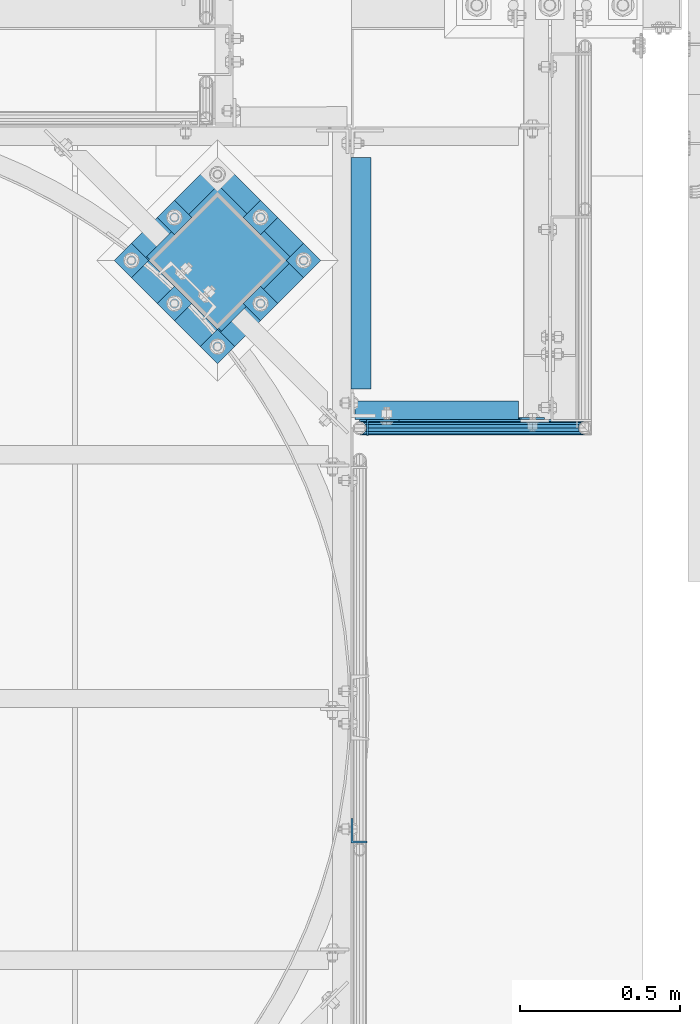
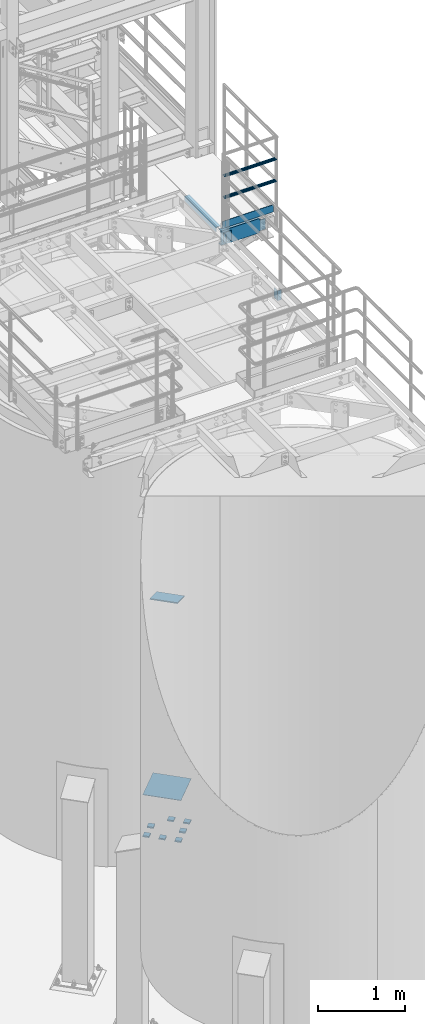
# One storey, part 1143 of 1876: 15 beams, 1 member, 6 elements without a shape of their own.
"""IFC2X3 building model written with IfcOpenShell, lengths in millimetres."""

from ifc_helpers import new_model, si_unit, frame, origin_with_axes, place, context, subcontext, project, spatial, faceted_brep, material, type_object, element, aggregate, save


model = new_model("IFC2X3")

# Units and contexts
model_context = context("Model", 3, precision=1e-05, world=origin_with_axes())
body_context = subcontext(model_context, "Body", "Model", "MODEL_VIEW")
ifc_project = project(units=[si_unit("LENGTHUNIT", "METRE", prefix="MILLI"), si_unit("AREAUNIT", "SQUARE_METRE"), si_unit("VOLUMEUNIT", "CUBIC_METRE"), si_unit("MASSUNIT", "GRAM", prefix="KILO"), si_unit("TIMEUNIT", "SECOND"), si_unit("PLANEANGLEUNIT", "RADIAN"), si_unit("SOLIDANGLEUNIT", "STERADIAN"), si_unit("THERMODYNAMICTEMPERATUREUNIT", "DEGREE_CELSIUS"), si_unit("LUMINOUSINTENSITYUNIT", "LUMEN")], contexts=[model_context])

# Site, building, storey
site_placement = place(None, origin_with_axes())
site = spatial("IfcSite", under=ifc_project, at=site_placement, CompositionType="ELEMENT")
building_placement = place(site_placement, origin_with_axes())
building = spatial("IfcBuilding", under=site, at=building_placement, Name="Undefined", CompositionType="ELEMENT")
storey_placement = place(building_placement, origin_with_axes())
storey = spatial("IfcBuildingStorey", under=building, at=storey_placement, Name="Undefined", CompositionType="ELEMENT", Elevation=0.0)

# Assembly, beams
assembly_1_placement = place(storey_placement, origin_with_axes())
assembly_1 = element("IfcElementAssembly", 1, at=assembly_1_placement, inside=storey, Name="HANDRAIL", AssemblyPlace="NOTDEFINED", PredefinedType="RIGID_FRAME")
ifc_material_1 = material(Name="STEEL/A36")
beam_type_1 = type_object("IfcBeamType", PredefinedType="NOTDEFINED")
beam_1_placement = place(assembly_1_placement, frame((7049.39088293518, -8686.8, 7896.225), z_axis=(0.0, 0.0, 1.0), x_axis=(0.0, 1.0, 0.0)))
beam_1 = element("IfcBeam", 2, at=beam_1_placement, type_object=beam_type_1, material=ifc_material_1, Name="PLATE", context=body_context, shape_type="Brep", body=[
    faceted_brep([(0.0, -3.17500000000018, -69.8499999999999), (0.0, -3.17500000000018, 69.8499999999999), (0.0, 3.17500000000018, 69.8499999999999), (0.0, 3.17500000000018, -69.8499999999999), (50.7999992370605, 3.17500000000018, 69.8500000000004), (50.7999992370605, 3.17500000000018, -69.8500000000004), (44.449999237062, -3.17500000000018, -69.8500000000004), (44.449999237062, -3.17500000000018, 69.8500000000004), (50.7999992370605, -98.4249984741218, 69.8500000000004), (50.7999992370605, -98.4249984741218, -69.8500000000004), (44.449999237062, -98.4249984741218, 69.8500000000004), (44.449999237062, -98.4249984741218, -69.8500000000004)], [[[0, 1, 2, 3]], [[3, 2, 4, 5]], [[1, 0, 6, 7]], [[5, 4, 8, 9]], [[4, 2, 1, 7, 10, 8]], [[7, 6, 11, 10]], [[6, 0, 3, 5, 9, 11]], [[10, 11, 9, 8]]]),
])
ifc_material_2 = material()
beam_type_2 = type_object("IfcBeamType", Name="PIPE1-1/4STD", PredefinedType="NOTDEFINED")
beam_2_placement = place(assembly_1_placement, frame((7025.13388293407, -8663.43199999895, 8480.425), z_axis=(0.0, 0.0, -1.0), x_axis=(1.0, 0.0, 0.0)))
beam_2 = element("IfcBeam", 3, at=beam_2_placement, type_object=beam_type_2, material=ifc_material_2, Name="HANDRAIL", ObjectType="PIPE1-1/4STD", context=body_context, shape_type="Brep", body=[
    faceted_brep([(9.09494701772928e-13, 21.0820000000003, 0.0), (10.5409999957128, 18.2575475579433, -10.5409999999993), (10.5409999999983, 18.2575475625836, 10.5410000000011), (10.5409999999983, -18.2575475625836, 10.5410000000011), (10.5409999957128, -18.2575475672238, -10.5409999999993), (9.09494701772928e-13, -21.0820000000003, 0.0), (18.2575475625817, -10.5410000000011, 18.2575475625836), (18.2575475625817, -10.5409999999974, 13.3999612267289), (13.6205863358537, -15.1779612267255, 8.76300000000083), (11.2725475625793, -17.5259999999998, 0.0), (13.6205863358537, -15.1779612267255, -8.76299999999901), (18.2575475625817, -10.5409999999974, -13.3999612267271), (18.2575475625817, -10.5410000000011, -18.2575475625836), (21.0819999999985, 0.0, -17.5259999999998), (21.0819999999985, 0.0, -21.0819999999985), (18.7339612267233, -8.76300000000083, -15.1779612267255), (18.7339612267251, 8.76299999999901, -15.1779612267255), (18.2575475625817, 10.5410000000011, -13.3999612267235), (18.2575475625817, 10.5409999999993, -18.2575475625836), (13.6205863358573, 15.1779612267255, -8.76299999999901), (11.2725475625839, 17.5259999999998, 0.0), (13.6205863358573, 15.1779612267255, 8.76300000000083), (18.2575475625817, 10.5410000000011, 13.3999612267253), (18.2575475625817, 10.5409999999993, 18.2575475625836), (18.7339612267251, 8.76299999999901, 15.1779612267273), (21.0819999999985, 1.81898940354586e-12, 17.5259999999998), (21.0819999999985, 1.81898940354586e-12, 21.0820000000003), (18.7339612267233, -8.76300000000083, 15.1779612267273), (704.848117064815, 21.0820000000003, 0.0), (694.30711706593, 18.2575475625836, -10.5409999999993), (686.590569503347, 10.5409999999993, -18.2575475625836), (704.848117065931, -21.0819999989562, 0.0), (694.30711706593, -18.2575475625836, -10.5409999999993), (694.30711706593, -18.2575475625836, 10.5409999999993), (686.590569503347, -10.5409999999993, 18.2575475625836), (686.590569503347, -10.5409999999993, -18.2575475625836), (683.76611706593, 0.0, -21.0820000000003), (686.114155838924, 8.76300000000083, -15.1779612267255), (683.76611706593, 0.0, -17.5259999999998), (686.590569503347, 10.5410000010434, -13.3999612256812), (686.590569503347, -10.5409999989552, -13.3999612277694), (686.114155839485, -8.76300000000083, -15.1779612267255), (691.227530731117, -15.1779612267255, -8.76300000000083), (693.575569504391, -17.5259999999998, 0.0), (691.227530731117, -15.1779612267255, 8.76300000000083), (686.590569503347, -10.5409999989552, 13.3999612277694), (686.114155839484, -8.76300000000083, 15.1779612267255), (683.76611706593, 0.0, 17.5259999999998), (683.76611706593, 0.0, 21.0820000000003), (686.590569503347, 10.5409999999993, 18.2575475625836), (694.30711706593, 18.2575475625836, 10.5409999999993), (686.590569503347, 10.5410000010434, 13.3999612256812), (691.227530729029, 15.1779612267255, 8.76300000000083), (693.575569502303, 17.5259999999998, 0.0), (691.227530729029, 15.1779612267255, -8.76300000000083), (686.114155838924, 8.76300000000083, 15.1779612267255)], [[[0, 1, 2]], [[3, 4, 5]], [[6, 7, 8, 9, 10, 11, 12, 4, 3]], [[13, 14, 12, 11, 15]], [[16, 17, 18, 14, 13]], [[2, 1, 18, 17, 19, 20, 21, 22, 23]], [[23, 22, 24, 25, 26]], [[26, 25, 27, 7, 6]], [[28, 29, 1, 0]], [[29, 30, 18, 1]], [[31, 32, 33]], [[33, 34, 6, 3]], [[31, 33, 3, 5]], [[32, 31, 5, 4]], [[35, 32, 4, 12]], [[36, 35, 12, 14]], [[30, 36, 14, 18]], [[37, 38, 36, 30, 39]], [[40, 35, 36, 38, 41]], [[33, 32, 35, 40, 42, 43, 44, 45, 34]], [[34, 45, 46, 47, 48]], [[34, 48, 26, 6]], [[49, 50, 2, 23]], [[48, 49, 23, 26]], [[50, 28, 0, 2]], [[28, 50, 29]], [[49, 51, 52, 53, 54, 39, 30, 29, 50]], [[48, 47, 55, 51, 49]], [[55, 47, 25, 24]], [[21, 52, 51, 55, 24, 22]], [[53, 52, 21, 20]], [[54, 53, 20, 19]], [[37, 39, 54, 19, 17, 16]], [[38, 37, 16, 13]], [[41, 38, 13, 15]], [[10, 42, 40, 41, 15, 11]], [[43, 42, 10, 9]], [[44, 43, 9, 8]], [[46, 45, 44, 8, 7, 27]], [[47, 46, 27, 25]]]),
])
beam_3_placement = place(assembly_1_placement, frame((7025.13388293407, -8663.43200000567, 8785.225), z_axis=(0.0, 0.0, -1.0), x_axis=(1.0, 0.0, 0.0)))
beam_3 = element("IfcBeam", 4, at=beam_3_placement, type_object=beam_type_2, material=ifc_material_2, Name="HANDRAIL", ObjectType="PIPE1-1/4STD", context=body_context, shape_type="Brep", body=[
    faceted_brep([(9.09494701772928e-13, 21.0820000000003, 0.0), (10.5409999957128, 18.2575475579433, -10.5409999999993), (10.5409999999983, 18.2575475625836, 10.5410000000011), (10.5409999999983, -18.2575475625836, 10.5410000000011), (10.5409999957128, -18.2575475672238, -10.5409999999993), (9.09494701772928e-13, -21.0820000000003, 0.0), (18.2575475625817, -10.5410000000011, 18.2575475625836), (18.2575475625817, -10.5409999999974, 13.3999612267289), (13.6205863358537, -15.1779612267255, 8.76300000000083), (11.2725475625793, -17.5259999999998, 0.0), (13.6205863358537, -15.1779612267255, -8.76299999999901), (18.2575475625817, -10.5409999999974, -13.3999612267271), (18.2575475625817, -10.5410000000011, -18.2575475625836), (21.0819999999985, 0.0, -17.5259999999998), (21.0819999999985, 0.0, -21.0819999999985), (18.7339612267233, -8.76300000000083, -15.1779612267255), (18.7339612267251, 8.76299999999901, -15.1779612267255), (18.2575475625817, 10.5410000000011, -13.3999612267235), (18.2575475625817, 10.5409999999993, -18.2575475625836), (13.6205863358573, 15.1779612267255, -8.76299999999901), (11.2725475625839, 17.5259999999998, 0.0), (13.6205863358573, 15.1779612267255, 8.76300000000083), (18.2575475625817, 10.5410000000011, 13.3999612267253), (18.2575475625817, 10.5409999999993, 18.2575475625836), (18.7339612267251, 8.76299999999901, 15.1779612267273), (21.0819999999985, 1.81898940354586e-12, 17.5259999999998), (21.0819999999985, 1.81898940354586e-12, 21.0820000000003), (18.7339612267233, -8.76300000000083, 15.1779612267273), (704.848117064815, 21.0820000000003, 0.0), (694.30711706593, 18.2575475625836, -10.5409999999993), (686.590569503347, 10.5409999999993, -18.2575475625836), (704.848117065931, -21.0819999989562, 0.0), (694.30711706593, -18.2575475625836, -10.5409999999993), (694.30711706593, -18.2575475625836, 10.5409999999993), (686.590569503347, -10.5409999999993, 18.2575475625836), (686.590569503347, -10.5409999999993, -18.2575475625836), (683.76611706593, 0.0, -21.0820000000003), (686.114155838924, 8.76300000000083, -15.1779612267255), (683.76611706593, 0.0, -17.5259999999998), (686.590569503347, 10.5410000010434, -13.3999612256812), (686.590569503347, -10.5409999989552, -13.3999612277694), (686.114155839485, -8.76300000000083, -15.1779612267255), (691.227530731117, -15.1779612267255, -8.76300000000083), (693.575569504391, -17.5259999999998, 0.0), (691.227530731117, -15.1779612267255, 8.76300000000083), (686.590569503347, -10.5409999989552, 13.3999612277694), (686.114155839484, -8.76300000000083, 15.1779612267255), (683.76611706593, 0.0, 17.5259999999998), (683.76611706593, 0.0, 21.0820000000003), (686.590569503347, 10.5409999999993, 18.2575475625836), (694.30711706593, 18.2575475625836, 10.5409999999993), (686.590569503347, 10.5410000010434, 13.3999612256812), (691.227530729029, 15.1779612267255, 8.76300000000083), (693.575569502303, 17.5259999999998, 0.0), (691.227530729029, 15.1779612267255, -8.76300000000083), (686.114155838924, 8.76300000000083, 15.1779612267255)], [[[0, 1, 2]], [[3, 4, 5]], [[6, 7, 8, 9, 10, 11, 12, 4, 3]], [[13, 14, 12, 11, 15]], [[16, 17, 18, 14, 13]], [[2, 1, 18, 17, 19, 20, 21, 22, 23]], [[23, 22, 24, 25, 26]], [[26, 25, 27, 7, 6]], [[28, 29, 1, 0]], [[29, 30, 18, 1]], [[31, 32, 33]], [[33, 34, 6, 3]], [[31, 33, 3, 5]], [[32, 31, 5, 4]], [[35, 32, 4, 12]], [[36, 35, 12, 14]], [[30, 36, 14, 18]], [[37, 38, 36, 30, 39]], [[40, 35, 36, 38, 41]], [[33, 32, 35, 40, 42, 43, 44, 45, 34]], [[34, 45, 46, 47, 48]], [[34, 48, 26, 6]], [[49, 50, 2, 23]], [[48, 49, 23, 26]], [[50, 28, 0, 2]], [[28, 50, 29]], [[49, 51, 52, 53, 54, 39, 30, 29, 50]], [[48, 47, 55, 51, 49]], [[55, 47, 25, 24]], [[21, 52, 51, 55, 24, 22]], [[53, 52, 21, 20]], [[54, 53, 20, 19]], [[37, 39, 54, 19, 17, 16]], [[38, 37, 16, 13]], [[41, 38, 13, 15]], [[10, 42, 40, 41, 15, 11]], [[43, 42, 10, 9]], [[44, 43, 9, 8]], [[46, 45, 44, 8, 7, 27]], [[47, 46, 27, 25]]]),
])

# Assembly, beam
assembly_2_placement = place(storey_placement, origin_with_axes())
assembly_2 = element("IfcElementAssembly", 5, at=assembly_2_placement, inside=storey, Name="BEAM", AssemblyPlace="NOTDEFINED", PredefinedType="RIGID_FRAME")
beam_type_3 = type_object("IfcBeamType", Name="L2-1/2X2-1/2X1/4", PredefinedType="NOTDEFINED")
beam_4_placement = place(assembly_2_placement, frame((7029.45047584742, -8540.75, 7966.075), z_axis=(1.0, 0.0, 0.0), x_axis=(0.0, 1.0, 0.0)))
beam_4 = element("IfcBeam", 6, at=beam_4_placement, type_object=beam_type_3, material=ifc_material_1, Name="ANGLE", ObjectType="L2-1/2X2-1/2X1/4", context=body_context, shape_type="Brep", body=[
    faceted_brep([(0.0, 31.75, -31.75), (0.0, 31.75, 31.75), (723.935595704369, 31.75, 31.75), (723.935595704369, 31.75, -31.75), (0.0, 25.3999999999996, 31.75), (723.935595704369, 25.3999999999996, 31.75), (0.0, 25.3999999999996, -25.3999999999996), (723.935595704369, 25.3999999999996, -25.3999999999996), (0.0, -31.75, -25.3999999999996), (723.935595704369, -31.75, -25.3999999999996), (0.0, -31.75, -31.75), (723.935595704369, -31.75, -31.75)], [[[0, 1, 2, 3]], [[1, 4, 5, 2]], [[4, 6, 7, 5]], [[6, 8, 9, 7]], [[8, 10, 11, 9]], [[10, 0, 3, 11]], [[5, 7, 9, 11, 3, 2]], [[10, 8, 6, 4, 1, 0]]]),
])
aggregate(assembly_2, [beam_4])

# Beam
beam_type_4 = type_object("IfcBeamType", PredefinedType="NOTDEFINED")
beam_5_placement = place(assembly_1_placement, frame((7025.13388293518, -8639.175, 8080.375), z_axis=(0.0, 0.0, 1.0), x_axis=(1.0, 0.0, 0.0)))
beam_5 = element("IfcBeam", 7, at=beam_5_placement, type_object=beam_type_4, material=ifc_material_1, Name="PLATE", context=body_context, shape_type="Brep", body=[
    faceted_brep([(0.0, 3.17500000000018, -50.8000000000002), (0.0, 3.17500000000018, 50.8000000000002), (677.416117064815, 3.17499999999927, 50.8000000000002), (677.416117064815, 3.17499999999927, -50.8000000000002), (0.0, -3.17500000000018, 50.8000000000002), (677.416117064815, -3.17499999999927, 50.8000000000002), (0.0, -3.17500000000018, -50.8000000000002), (677.416117064815, -3.17499999999927, -50.8000000000002)], [[[0, 1, 2, 3]], [[1, 4, 5, 2]], [[4, 6, 7, 5]], [[6, 0, 3, 7]], [[5, 7, 3, 2]], [[6, 4, 1, 0]]]),
])

aggregate(assembly_1, [beam_5, beam_1, beam_2, beam_3])

# Assembly, beam
assembly_3_placement = place(storey_placement, origin_with_axes())
assembly_3 = element("IfcElementAssembly", 8, at=assembly_3_placement, inside=storey, Name="HANDRAIL", AssemblyPlace="NOTDEFINED", PredefinedType="RIGID_FRAME")
beam_type_5 = type_object("IfcBeamType", Name="L3X2X1/4", PredefinedType="NOTDEFINED")
beam_6_placement = place(assembly_3_placement, frame((7023.10047584742, -9922.98235546873, 7966.075), z_axis=(0.0, 1.0, 0.0), x_axis=(0.0, 0.0, -1.0)))
beam_6 = element("IfcBeam", 9, at=beam_6_placement, type_object=beam_type_5, material=ifc_material_1, Name="ANGLE", ObjectType="L3X2X1/4", context=body_context, shape_type="Brep", body=[
    faceted_brep([(0.0, 25.3999999999996, -38.1000000000004), (0.0, 25.3999999999996, 38.1000000000004), (139.7, 25.3999999999996, 38.1000000000004), (139.7, 25.3999999999996, -38.1000000000004), (0.0, 19.0500000000002, 38.1000000000004), (139.7, 19.0500000000002, 38.1000000000004), (0.0, 19.0500000000002, -31.75), (139.7, 19.0500000000002, -31.75), (0.0, -25.3999999999996, -31.75), (139.7, -25.3999999999996, -31.75), (0.0, -25.3999999999996, -38.1000000000004), (139.7, -25.3999999999996, -38.1000000000004)], [[[0, 1, 2, 3]], [[1, 4, 5, 2]], [[4, 6, 7, 5]], [[6, 8, 9, 7]], [[8, 10, 11, 9]], [[10, 0, 3, 11]], [[5, 7, 9, 11, 3, 2]], [[10, 8, 6, 4, 1, 0]]]),
])
aggregate(assembly_3, [beam_6])

assembly_4_placement = place(storey_placement, origin_with_axes())
assembly_4 = element("IfcElementAssembly", 10, at=assembly_4_placement, inside=storey, Name="BEAM", AssemblyPlace="NOTDEFINED", PredefinedType="RIGID_FRAME")
beam_type_6 = type_object("IfcBeamType", Name="C8X11.5", PredefinedType="NOTDEFINED")
beam_7_placement = place(assembly_4_placement, frame((6997.70047584742, -8607.425, 7896.225), z_axis=(0.0, 0.0, -1.0), x_axis=(1.0, 0.0, 0.0)))
beam_7 = element("IfcBeam", 11, at=beam_7_placement, type_object=beam_type_6, material=ifc_material_1, Name="BEAM", ObjectType="C8X11.5", context=body_context, shape_type="Brep", body=[
    faceted_brep([(523.874524152585, -28.5750000000007, -96.8355949999996), (523.874524152585, -28.5750000000007, -101.6), (523.874524152585, 28.5750000000007, -101.6), (523.874524152585, 28.5750000000007, -88.899999809265), (523.874524152585, 19.0576241940871, -88.899999809265), (523.979487187225, 22.2250000000004, -88.3723149999996), (524.841254075172, 28.5750000000007, -84.0399202912195), (524.841254075172, 22.2250000000004, -84.0399202912195), (527.594267975651, 28.5750000000007, -79.9197438230658), (527.594267975651, 22.2250000000004, -79.9197438230658), (531.714444443804, 28.5750000000007, -77.1667299225874), (531.714444443804, 22.2250000000004, -77.1667299225874), (536.57452396185, 28.5750000000007, -76.1999999999998), (536.57452396185, 22.2250000000004, -76.1999999999998), (606.424524152584, 22.2250000000004, -76.1999999999998), (606.424524152584, 28.5750000000007, -76.1999999999998), (12.7000000000007, 28.5749999999998, 101.6), (12.7000000000007, -28.5749999999998, 101.6), (523.874524152585, -28.5750000000007, 101.6), (523.874524152585, 28.5750000000007, 101.6), (12.7000000000007, -28.5749999999998, -101.6), (12.7000000000007, -28.5749999999998, -96.8355949999996), (12.7000000000007, 22.2250000000004, -88.3723149999996), (12.7000000000007, 22.2250000000004, 88.3723149999996), (12.7000000000007, -28.5749999999998, 96.8355949999996), (12.7000000000007, 28.5749999999998, -101.6), (523.874524152585, -28.5750000000007, 96.8355949999996), (523.874524152585, 19.0576241940871, 88.899999809265), (523.874524152585, 28.5750000000007, 88.899999809265), (523.979487187226, 22.2250000000004, 88.3723149999996), (524.841254075172, 22.2250000000004, 84.0399202912195), (524.841254075172, 28.5750000000007, 84.0399202912195), (527.594267975651, 22.2250000000004, 79.9197438230658), (527.594267975651, 28.5750000000007, 79.9197438230658), (531.714444443804, 22.2250000000004, 77.1667299225874), (531.714444443804, 28.5750000000007, 77.1667299225874), (536.57452396185, 22.2250000000004, 76.1999999999998), (536.57452396185, 28.5750000000007, 76.1999999999998), (606.424524152584, 22.2250000000004, 76.1999999999998), (606.424524152584, 28.5750000000007, 76.1999999999998)], [[[0, 1, 2, 3, 4]], [[5, 4, 3, 6, 7]], [[7, 6, 8, 9]], [[9, 8, 10, 11]], [[11, 10, 12, 13]], [[14, 13, 12, 15]], [[16, 17, 18, 19]], [[20, 21, 22, 23, 24, 17, 16, 25]], [[17, 24, 26, 18]], [[18, 26, 27, 28, 19]], [[24, 23, 29, 27, 26]], [[30, 31, 28, 27, 29]], [[32, 33, 31, 30]], [[34, 35, 33, 32]], [[36, 37, 35, 34]], [[38, 39, 37, 36]], [[39, 38, 14, 15]], [[10, 8, 6, 3, 2, 25, 16, 19, 28, 31, 33, 35, 37, 39, 15, 12]], [[20, 25, 2, 1]], [[21, 20, 1, 0]], [[22, 21, 0, 4, 5]], [[38, 36, 34, 32, 30, 29, 23, 22, 5, 7, 9, 11, 13, 14]]]),
])
aggregate(assembly_4, [beam_7])

# Assembly, member
assembly_5_placement = place(storey_placement, origin_with_axes())
assembly_5 = element("IfcElementAssembly", 12, at=assembly_5_placement, inside=storey, Name="COLUMN", AssemblyPlace="NOTDEFINED", PredefinedType="RIGID_FRAME")
member_type = type_object("IfcMemberType", PredefinedType="NOTDEFINED")
member_placement = place(assembly_5_placement, frame((6474.05084607542, -8245.25246834792, 2749.16704814523), z_axis=(0.707106781186547, -0.707106781186548, 0.0), x_axis=(0.664463024761457, 0.664463024761457, -0.342020141877214)))
member = element("IfcMember", 13, at=member_placement, type_object=member_type, material=ifc_material_1, Name="PLATE", context=body_context, shape_type="Brep", body=[
    faceted_brep([(0.0, 6.35000000000042, -165.100000000026), (0.0, 6.35000000000042, 165.100000000029), (337.061384869998, 6.34999999999997, 165.099999999921), (337.061384869996, 6.34999999999997, -165.100000000135), (1.81898940354586e-12, -6.34999999999849, 165.100000000029), (337.061384869998, -6.3499999999994, 165.099999999921), (0.0, -6.34999999999894, -165.100000000026), (337.061384869998, -6.3499999999994, -165.100000000136)], [[[0, 1, 2, 3]], [[1, 4, 5, 2]], [[4, 6, 7, 5]], [[6, 0, 3, 7]], [[5, 7, 3, 2]], [[6, 4, 1, 0]]]),
])
aggregate(assembly_5, [member])

# Assembly, beams
assembly_6_placement = place(storey_placement, origin_with_axes())
assembly_6 = element("IfcElementAssembly", 14, at=assembly_6_placement, inside=storey, Name="TEMPLATE", AssemblyPlace="NOTDEFINED", PredefinedType="RIGID_FRAME")
beam_type_7 = type_object("IfcBeamType", PredefinedType="NOTDEFINED")
beam_8_placement = place(assembly_6_placement, frame((6876.62665728854, -8112.08434078037, -542.925), z_axis=(-0.707106781186548, 0.707106781186547, 0.0), x_axis=(-0.707106781186547, -0.707106781186548, 0.0)))
beam_8 = element("IfcBeam", 15, at=beam_8_placement, type_object=beam_type_7, material=ifc_material_1, Name="PLATE", context=body_context, shape_type="Brep", body=[
    faceted_brep([(0.0, 9.52499999999998, -38.1000000000058), (-9.09494701772928e-13, 9.52499999999998, 38.1000000000076), (76.2000000000762, 9.52499999999998, 38.1000000000058), (76.2000000000762, 9.52499999999998, -38.1000000000058), (-9.09494701772928e-13, -9.52499999999998, 38.1000000000076), (76.2000000000762, -9.52499999999998, 38.1000000000058), (0.0, -9.52499999999998, -38.1000000000058), (76.2000000000762, -9.52499999999998, -38.1000000000058)], [[[0, 1, 2, 3]], [[1, 4, 5, 2]], [[4, 6, 7, 5]], [[6, 0, 3, 7]], [[5, 7, 3, 2]], [[6, 4, 1, 0]]]),
])
beam_9_placement = place(assembly_6_placement, frame((6741.92281547239, -7977.38049896422, -542.925), z_axis=(-0.707106781186548, 0.707106781186547, 0.0), x_axis=(-0.707106781186547, -0.707106781186548, 0.0)))
beam_9 = element("IfcBeam", 16, at=beam_9_placement, type_object=beam_type_7, material=ifc_material_1, Name="PLATE", context=body_context, shape_type="Brep", body=[
    faceted_brep([(0.0, 9.52499999999998, -38.1000000000058), (-9.09494701772928e-13, 9.52499999999998, 38.1000000000076), (76.2000000000762, 9.52499999999998, 38.1000000000058), (76.2000000000762, 9.52499999999998, -38.1000000000058), (-9.09494701772928e-13, -9.52499999999998, 38.1000000000076), (76.2000000000762, -9.52499999999998, 38.1000000000058), (0.0, -9.52499999999998, -38.1000000000058), (76.2000000000762, -9.52499999999998, -38.1000000000058)], [[[0, 1, 2, 3]], [[1, 4, 5, 2]], [[4, 6, 7, 5]], [[6, 0, 3, 7]], [[5, 7, 3, 2]], [[6, 4, 1, 0]]]),
])
beam_10_placement = place(assembly_6_placement, frame((6741.92281547239, -8246.78818259652, -542.925), z_axis=(-0.707106781186548, 0.707106781186547, 0.0), x_axis=(-0.707106781186547, -0.707106781186548, 0.0)))
beam_10 = element("IfcBeam", 17, at=beam_10_placement, type_object=beam_type_7, material=ifc_material_1, Name="PLATE", context=body_context, shape_type="Brep", body=[
    faceted_brep([(0.0, 9.52499999999998, -38.1000000000058), (-9.09494701772928e-13, 9.52499999999998, 38.1000000000076), (76.2000000000762, 9.52499999999998, 38.1000000000058), (76.2000000000762, 9.52499999999998, -38.1000000000058), (-9.09494701772928e-13, -9.52499999999998, 38.1000000000076), (76.2000000000762, -9.52499999999998, 38.1000000000058), (0.0, -9.52499999999998, -38.1000000000058), (76.2000000000762, -9.52499999999998, -38.1000000000058)], [[[0, 1, 2, 3]], [[1, 4, 5, 2]], [[4, 6, 7, 5]], [[6, 0, 3, 7]], [[5, 7, 3, 2]], [[6, 4, 1, 0]]]),
])
beam_11_placement = place(assembly_6_placement, frame((6472.51513184009, -7977.38049896422, -542.925), z_axis=(-0.707106781186548, 0.707106781186547, 0.0), x_axis=(-0.707106781186547, -0.707106781186548, 0.0)))
beam_11 = element("IfcBeam", 18, at=beam_11_placement, type_object=beam_type_7, material=ifc_material_1, Name="PLATE", context=body_context, shape_type="Brep", body=[
    faceted_brep([(0.0, 9.52499999999998, -38.1000000000058), (-9.09494701772928e-13, 9.52499999999998, 38.1000000000076), (76.2000000000762, 9.52499999999998, 38.1000000000058), (76.2000000000762, 9.52499999999998, -38.1000000000058), (-9.09494701772928e-13, -9.52499999999998, 38.1000000000076), (76.2000000000762, -9.52499999999998, 38.1000000000058), (0.0, -9.52499999999998, -38.1000000000058), (76.2000000000762, -9.52499999999998, -38.1000000000058)], [[[0, 1, 2, 3]], [[1, 4, 5, 2]], [[4, 6, 7, 5]], [[6, 0, 3, 7]], [[5, 7, 3, 2]], [[6, 4, 1, 0]]]),
])
beam_12_placement = place(assembly_6_placement, frame((6607.21897365624, -8381.49202441267, -542.925), z_axis=(-0.707106781186548, 0.707106781186547, 0.0), x_axis=(-0.707106781186547, -0.707106781186548, 0.0)))
beam_12 = element("IfcBeam", 19, at=beam_12_placement, type_object=beam_type_7, material=ifc_material_1, Name="PLATE", context=body_context, shape_type="Brep", body=[
    faceted_brep([(0.0, 9.52499999999998, -38.1000000000058), (-9.09494701772928e-13, 9.52499999999998, 38.1000000000076), (76.2000000000762, 9.52499999999998, 38.1000000000058), (76.2000000000762, 9.52499999999998, -38.1000000000058), (-9.09494701772928e-13, -9.52499999999998, 38.1000000000076), (76.2000000000762, -9.52499999999998, 38.1000000000058), (0.0, -9.52499999999998, -38.1000000000058), (76.2000000000762, -9.52499999999998, -38.1000000000058)], [[[0, 1, 2, 3]], [[1, 4, 5, 2]], [[4, 6, 7, 5]], [[6, 0, 3, 7]], [[5, 7, 3, 2]], [[6, 4, 1, 0]]]),
])
beam_13_placement = place(assembly_6_placement, frame((6472.51513184009, -8246.78818259652, -542.925), z_axis=(-0.707106781186548, 0.707106781186547, 0.0), x_axis=(-0.707106781186547, -0.707106781186548, 0.0)))
beam_13 = element("IfcBeam", 20, at=beam_13_placement, type_object=beam_type_7, material=ifc_material_1, Name="PLATE", context=body_context, shape_type="Brep", body=[
    faceted_brep([(0.0, 9.52499999999998, -38.1000000000058), (-9.09494701772928e-13, 9.52499999999998, 38.1000000000076), (76.2000000000762, 9.52499999999998, 38.1000000000058), (76.2000000000762, 9.52499999999998, -38.1000000000058), (-9.09494701772928e-13, -9.52499999999998, 38.1000000000076), (76.2000000000762, -9.52499999999998, 38.1000000000058), (0.0, -9.52499999999998, -38.1000000000058), (76.2000000000762, -9.52499999999998, -38.1000000000058)], [[[0, 1, 2, 3]], [[1, 4, 5, 2]], [[4, 6, 7, 5]], [[6, 0, 3, 7]], [[5, 7, 3, 2]], [[6, 4, 1, 0]]]),
])
beam_14_placement = place(assembly_6_placement, frame((6337.81129002394, -8112.08434078037, -542.925), z_axis=(-0.707106781186548, 0.707106781186547, 0.0), x_axis=(-0.707106781186547, -0.707106781186548, 0.0)))
beam_14 = element("IfcBeam", 21, at=beam_14_placement, type_object=beam_type_7, material=ifc_material_1, Name="PLATE", context=body_context, shape_type="Brep", body=[
    faceted_brep([(0.0, 9.52499999999998, -38.1000000000058), (-9.09494701772928e-13, 9.52499999999998, 38.1000000000076), (76.2000000000762, 9.52499999999998, 38.1000000000058), (76.2000000000762, 9.52499999999998, -38.1000000000058), (-9.09494701772928e-13, -9.52499999999998, 38.1000000000076), (76.2000000000762, -9.52499999999998, 38.1000000000058), (0.0, -9.52499999999998, -38.1000000000058), (76.2000000000762, -9.52499999999998, -38.1000000000058)], [[[0, 1, 2, 3]], [[1, 4, 5, 2]], [[4, 6, 7, 5]], [[6, 0, 3, 7]], [[5, 7, 3, 2]], [[6, 4, 1, 0]]]),
])
beam_type_8 = type_object("IfcBeamType", PredefinedType="NOTDEFINED")
beam_15_placement = place(assembly_6_placement, frame((6741.92281547226, -7977.38049896414, 40.4815), z_axis=(0.707106781186547, -0.707106781186548, 0.0), x_axis=(-0.707106781186547, -0.707106781186548, 0.0)))
beam_15 = element("IfcBeam", 22, at=beam_15_placement, type_object=beam_type_8, material=ifc_material_1, Name="TEMPLATE", context=body_context, shape_type="Brep", body=[
    faceted_brep([(9.09494701772928e-13, 2.3815, -228.600000000035), (-9.09494701772928e-13, 2.3815, 228.60000000004), (457.200000000363, 2.3815, 228.60000000004), (457.200000000362, 2.3815, -228.600000000037), (-9.09494701772928e-13, -2.3815, 228.60000000004), (457.200000000363, -2.3815, 228.60000000004), (9.09494701772928e-13, -2.3815, -228.600000000035), (457.200000000362, -2.3815, -228.600000000037)], [[[0, 1, 2, 3]], [[1, 4, 5, 2]], [[4, 6, 7, 5]], [[6, 0, 3, 7]], [[5, 7, 3, 2]], [[6, 4, 1, 0]]]),
])
aggregate(assembly_6, [beam_8, beam_9, beam_10, beam_11, beam_12, beam_13, beam_14, beam_15])

save(model, "model.ifc")
